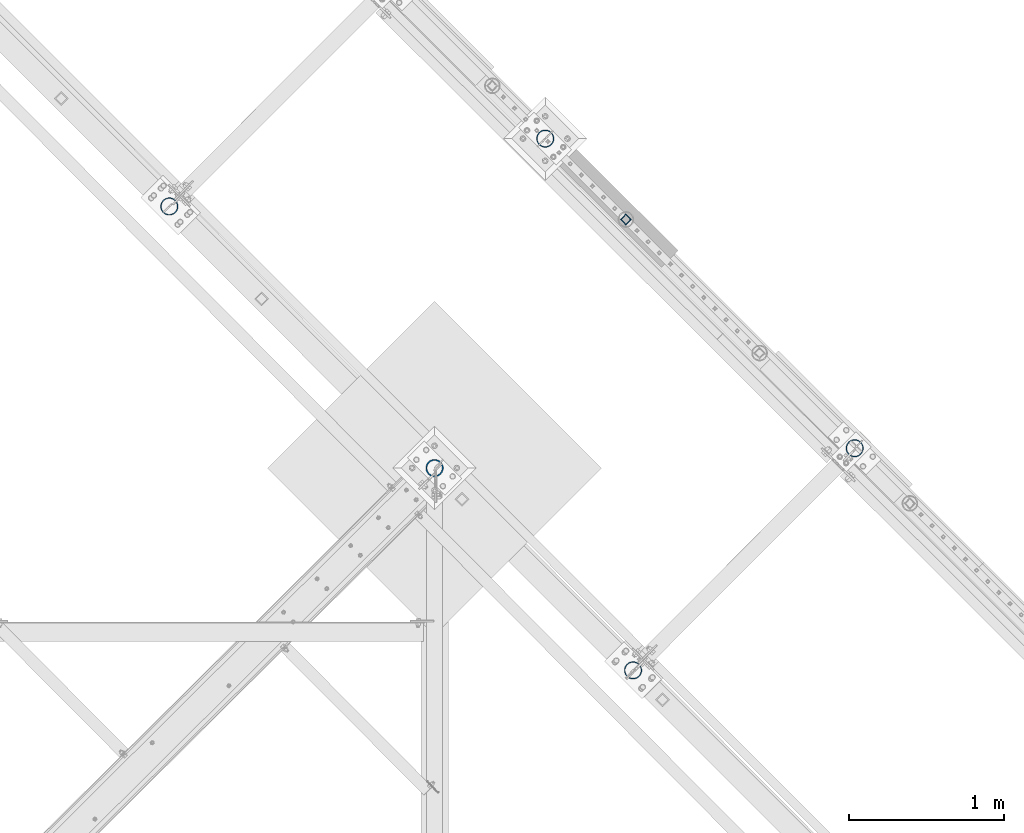
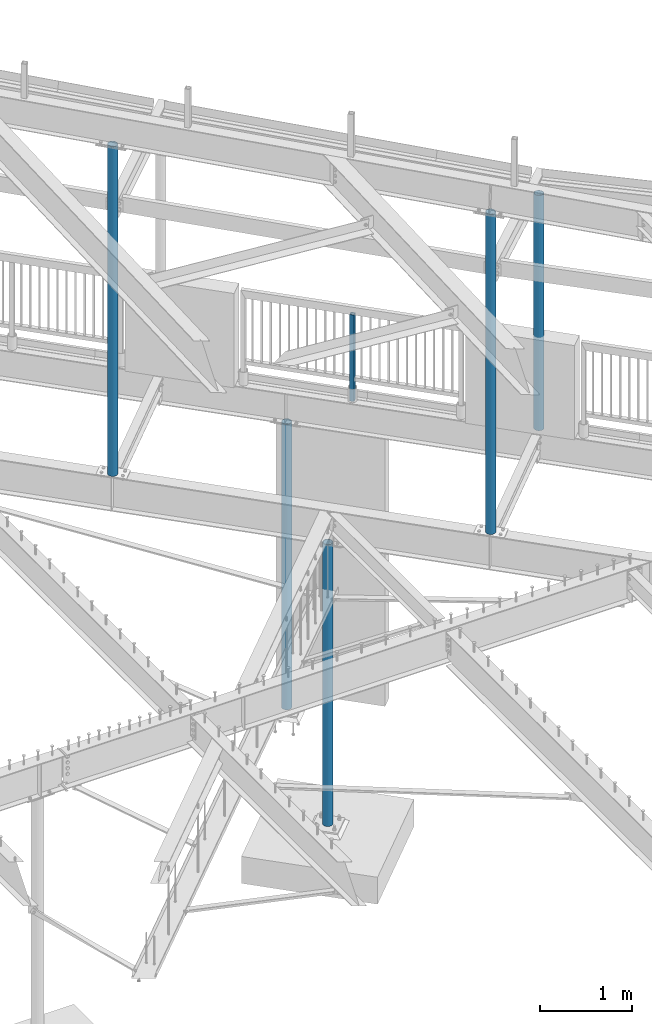
# One storey, part 138 of 975: 6 columns.
"""IFC2X3 building model written with IfcOpenShell, lengths in millimetres."""

from ifc_helpers import new_model, si_unit, frame, origin_with_axes, place, context, subcontext, project, spatial, faceted_brep, material, type_object, element, save


model = new_model("IFC2X3")

# Units and contexts
model_context = context("Model", 3, precision=1e-05, world=origin_with_axes())
body_context = subcontext(model_context, "Body", "Model", "MODEL_VIEW")
ifc_project = project(units=[si_unit("LENGTHUNIT", "METRE", prefix="MILLI"), si_unit("AREAUNIT", "SQUARE_METRE"), si_unit("VOLUMEUNIT", "CUBIC_METRE"), si_unit("MASSUNIT", "GRAM", prefix="KILO"), si_unit("TIMEUNIT", "SECOND"), si_unit("PLANEANGLEUNIT", "RADIAN"), si_unit("SOLIDANGLEUNIT", "STERADIAN"), si_unit("THERMODYNAMICTEMPERATUREUNIT", "DEGREE_CELSIUS"), si_unit("LUMINOUSINTENSITYUNIT", "LUMEN")], contexts=[model_context])

# Site, building, storey
site_placement = place(None, origin_with_axes())
site = spatial("IfcSite", under=ifc_project, at=site_placement, CompositionType="ELEMENT")
building_placement = place(site_placement, origin_with_axes())
building = spatial("IfcBuilding", under=site, at=building_placement, Name="Undefined", CompositionType="ELEMENT")
storey_placement = place(building_placement, origin_with_axes())
storey = spatial("IfcBuildingStorey", under=building, at=storey_placement, Name="Undefined", CompositionType="ELEMENT", Elevation=0.0)

# Columns
ifc_material_1 = material()
column_type_1 = type_object("IfcColumnType", Name="HSS2X2X.188_TUBES", PredefinedType="NOTDEFINED")
column_1_placement = place(storey_placement, frame((31066.8731973681, 17567.8342614889, 3937.00071954323), z_axis=(-0.707106781186601, 0.707106781186494, 2.36468622460961e-14), x_axis=(-5.04999999806568e-07, 5.04999999806568e-07, 0.999999999999745)))
element("IfcColumn", 1, at=column_1_placement, inside=storey, type_object=column_type_1, material=ifc_material_1, Name="HANDRAIL", ObjectType="HSS2X2X.188_TUBES", context=body_context, shape_type="Brep", body=[
    faceted_brep([(0.0, 20.6374999999753, -20.6375000000298), (0.0, -20.6375000000153, -20.6375000000153), (1142.9992657244, -20.6374999999534, -20.6375000019689), (1142.99926572435, 20.6374999999462, -20.6375000019689), (0.0, -20.6374999999825, 20.6375000000335), (1142.99929520217, -20.6374999999607, 20.6374999979416), (0.0, 20.6375000000116, 20.6375000000189), (1142.99929520212, 20.6374999999462, 20.6374999979416), (0.0, 25.3999999999724, -25.4000000000342), (0.0, 25.400000000016, 25.4000000000196), (1142.99929860339, 25.399999999936, 25.3999999979333), (1142.99926232306, 25.399999999936, -25.4000000019587), (0.0, -25.399999999976, 25.4000000000378), (1142.99929860346, -25.3999999999432, 25.3999999979333), (0.0, -25.400000000016, -25.4000000000196), (1142.99926232313, -25.3999999999432, -25.4000000019605)], [[[0, 1, 2, 3]], [[1, 4, 5, 2]], [[4, 6, 7, 5]], [[6, 0, 3, 7]], [[8, 9, 10, 11]], [[9, 12, 13, 10]], [[12, 14, 15, 13]], [[14, 8, 11, 15]], [[13, 15, 11, 10], [5, 7, 3, 2]], [[14, 12, 9, 8], [6, 4, 1, 0]]]),
])
ifc_material_2 = material(Name="STEEL/A53")
column_type_2 = type_object("IfcColumnType", Name="PIPE4STD", PredefinedType="NOTDEFINED")
column_2_placement = place(storey_placement, frame((31113.0694143629, 14658.8024995129, 3937.0), z_axis=(0.707106781186548, 0.707106781186548, 0.0), x_axis=(0.0, 0.0, 1.0)))
element("IfcColumn", 2, at=column_2_placement, inside=storey, type_object=column_type_2, material=ifc_material_2, Name="COLUMN", ObjectType="PIPE4STD", context=body_context, shape_type="Brep", body=[
    faceted_brep([(12.7000000000007, -51.1301999999359, 6.54836185276508e-11), (12.7000000000007, -48.6277098894352, 15.8001007258354), (4236.66741801943, -48.6277098894352, 15.8001007258354), (4236.74242044237, -51.1301999999359, 6.54836185276508e-11), (12.7000000000007, -41.3652007257788, 30.0535775067838), (4236.44958269599, -41.3652007257788, 30.0535775067838), (12.7000000000007, -30.0535775067819, 41.3652007257842), (4236.11023771126, -30.0535775067819, 41.3652007257842), (12.7000000000007, -15.8001007258317, 48.6277098894388), (4235.6826005167, -15.8001007258317, 48.6277098894388), (12.7000000000007, -6.00266503170133e-11, 51.1301999999414), (4235.20853122043, -6.00266503170133e-11, 51.1301999999414), (12.7000000000007, 15.8001007257153, 48.6277098894025), (4234.73443502822, 15.8001007257153, 48.6277098894025), (12.7000000000007, 30.0535775066819, 41.3652007257042), (4234.30671977857, 30.0535775066819, 41.3652007257042), (12.7000000000007, 41.3652007257078, 30.0535775066783), (4233.96725322019, 41.3652007257078, 30.0535775066783), (12.7000000000007, 48.6277098894061, 15.8001007257117), (4233.74926470502, 48.6277098894061, 15.8001007257117), (12.7000000000007, 51.1301999999469, -6.54836185276508e-11), (4233.67409246773, 51.1301999999469, -6.54836185276508e-11), (12.7000000000007, 48.6277098894425, -15.8001007258354), (4233.74909489068, 48.6277098894425, -15.8001007258354), (12.7000000000007, 41.3652007257861, -30.0535775067838), (4233.96693021412, 41.3652007257861, -30.0535775067838), (12.7000000000007, 30.0535775067892, -41.3652007257842), (4234.30627519885, 30.0535775067892, -41.3652007257842), (12.7000000000007, 15.800100725839, -48.6277098894388), (4234.73391239341, 15.800100725839, -48.6277098894388), (12.7000000000007, 7.09405867382884e-11, -51.1301999999414), (4235.20798168967, 7.09405867382884e-11, -51.1301999999414), (12.7000000000007, -15.8001007257044, -48.6277098893988), (4235.68207788189, -15.8001007257044, -48.6277098893988), (12.7000000000007, -30.0535775066746, -41.3652007257042), (4236.10979313153, -30.0535775066746, -41.3652007257042), (12.7000000000007, -41.3652007257006, -30.0535775066746), (4236.44925968991, -41.3652007257006, -30.0535775066746), (12.7000000000007, -48.6277098893952, -15.800100725708), (4236.66724820508, -48.6277098893952, -15.800100725708), (12.7000000000007, -57.149999999936, 7.27595761418343e-11), (12.7000000000007, -54.3528799061787, -17.6603212284354), (4236.83902219652, -54.3528799061787, -17.6603212284354), (4236.92304481644, -57.149999999936, 7.27595761418343e-11), (12.7000000000007, -46.2353212284306, -33.5919271684179), (4236.59536886361, -46.2353212284306, -33.5919271684179), (12.7000000000007, -33.5919271684143, -46.2353212284324), (4236.21593530358, -33.5919271684143, -46.2353212284324), (12.7000000000007, -17.6603212284317, -54.3528799061824), (4235.73786311694, -17.6603212284317, -54.3528799061824), (12.7000000000007, 7.45785655453801e-11, -57.149999999936), (4235.20794934025, 7.45785655453801e-11, -57.149999999936), (12.7000000000007, 17.6603212285845, -54.3528799062296), (4234.67806562609, 17.6603212285845, -54.3528799062296), (12.7000000000007, 33.5919271685379, -46.2353212285198), (4234.20008068433, 33.5919271685379, -46.2353212285198), (12.7000000000007, 46.2353212285234, -33.5919271685343), (4233.82078301138, 46.2353212285234, -33.5919271685343), (12.7000000000007, 54.3528799062333, -17.6603212285772), (4233.5773009062, 54.3528799062333, -17.6603212285772), (12.7000000000007, 57.1499999999414, -7.27595761418343e-11), (4233.49346809367, 57.1499999999414, -7.27595761418343e-11), (12.7000000000007, 54.3528799061896, 17.6603212284354), (4233.57749071359, 54.3528799061896, 17.6603212284354), (12.7000000000007, 46.2353212284361, 33.5919271684179), (4233.82114404649, 46.2353212284361, 33.5919271684179), (12.7000000000007, 33.5919271684197, 46.2353212284361), (4234.20057760653, 33.5919271684197, 46.2353212284361), (12.7000000000007, 17.6603212284426, 54.3528799061824), (4234.67864979317, 17.6603212284426, 54.3528799061824), (12.7000000000007, -6.91215973347425e-11, 57.1499999999396), (4235.20856356986, -6.91215973347425e-11, 57.1499999999396), (12.7000000000007, -17.6603212285736, 54.3528799062333), (4235.73844728401, -17.6603212285736, 54.3528799062333), (12.7000000000007, -33.5919271685307, 46.2353212285234), (4236.21643222577, -33.5919271685307, 46.2353212285234), (12.7000000000007, -46.2353212285161, 33.5919271685343), (4236.59572989872, -46.2353212285161, 33.5919271685343), (12.7000000000007, -54.3528799062224, 17.6603212285772), (4236.83921200391, -54.3528799062224, 17.6603212285772)], [[[0, 1, 2, 3]], [[1, 4, 5, 2]], [[4, 6, 7, 5]], [[6, 8, 9, 7]], [[8, 10, 11, 9]], [[10, 12, 13, 11]], [[12, 14, 15, 13]], [[14, 16, 17, 15]], [[16, 18, 19, 17]], [[18, 20, 21, 19]], [[20, 22, 23, 21]], [[22, 24, 25, 23]], [[24, 26, 27, 25]], [[26, 28, 29, 27]], [[28, 30, 31, 29]], [[30, 32, 33, 31]], [[32, 34, 35, 33]], [[34, 36, 37, 35]], [[36, 38, 39, 37]], [[38, 0, 3, 39]], [[40, 41, 42, 43]], [[41, 44, 45, 42]], [[44, 46, 47, 45]], [[46, 48, 49, 47]], [[48, 50, 51, 49]], [[50, 52, 53, 51]], [[52, 54, 55, 53]], [[54, 56, 57, 55]], [[56, 58, 59, 57]], [[58, 60, 61, 59]], [[60, 62, 63, 61]], [[62, 64, 65, 63]], [[64, 66, 67, 65]], [[66, 68, 69, 67]], [[68, 70, 71, 69]], [[70, 72, 73, 71]], [[72, 74, 75, 73]], [[74, 76, 77, 75]], [[76, 78, 79, 77]], [[78, 40, 43, 79]], [[45, 47, 49, 51, 53, 55, 57, 59, 61, 63, 65, 67, 69, 71, 73, 75, 77, 79, 43, 42], [5, 7, 9, 11, 13, 15, 17, 19, 21, 23, 25, 27, 29, 31, 33, 35, 37, 39, 3, 2]], [[78, 76, 74, 72, 70, 68, 66, 64, 62, 60, 58, 56, 54, 52, 50, 48, 46, 44, 41, 40], [38, 36, 34, 32, 30, 28, 26, 24, 22, 20, 18, 16, 14, 12, 10, 8, 6, 4, 1, 0]]]),
])
column_3_placement = place(storey_placement, frame((32542.8595833266, 16091.7904166791, 3937.0), z_axis=(0.707106781186548, 0.707106781186548, 0.0), x_axis=(0.0, 0.0, 1.0)))
element("IfcColumn", 3, at=column_3_placement, inside=storey, type_object=column_type_2, material=ifc_material_2, Name="COLUMN", ObjectType="PIPE4STD", context=body_context, shape_type="Brep", body=[
    faceted_brep([(12.7000000000007, -51.1301999999359, 6.54836185276508e-11), (12.7000000000007, -48.6277098894352, 15.8001007258354), (3112.73367698093, -48.6277098894407, 15.8001007258354), (3113.92291634242, -51.1301999999414, 6.54836185276508e-11), (12.7000000000007, -41.3652007257788, 30.0535775067838), (3111.66141610372, -41.3652007257788, 30.0535775067838), (12.7000000000007, -30.0535775067819, 41.3652007257842), (3110.81109407631, -30.0535775067819, 41.3652007257842), (12.7000000000007, -15.8001007258317, 48.6277098894388), (3110.2659463433, -15.8001007258335, 48.6277098894425), (12.7000000000007, -6.00266503170133e-11, 51.1301999999414), (3110.07933576305, -6.54836185276508e-11, 51.1301999999414), (12.7000000000007, 15.8001007257153, 48.6277098894025), (3110.26952907935, 15.8001007257099, 48.6277098893988), (12.7000000000007, 30.0535775066819, 41.3652007257042), (3110.81790884526, 30.0535775066801, 41.3652007257042), (12.7000000000007, 41.3652007257078, 30.0535775066783), (3111.67079582849, 41.3652007257078, 30.0535775066819), (12.7000000000007, 48.6277098894061, 15.8001007257117), (3112.74470350872, 48.6277098894006, 15.8001007257117), (12.7000000000007, 51.1301999999469, -6.54836185276508e-11), (3113.93451031984, 51.1301999999414, -6.54836185276508e-11), (12.7000000000007, 48.6277098894425, -15.8001007258354), (3115.12374968133, 48.6277098894407, -15.8001007258354), (12.7000000000007, 41.3652007257861, -30.0535775067838), (3116.19601055854, 41.3652007257842, -30.0535775067838), (12.7000000000007, 30.0535775067892, -41.3652007257842), (3117.04633258595, 30.0535775067874, -41.365200725777), (12.7000000000007, 15.800100725839, -48.6277098894388), (3117.59148031896, 15.8001007258335, -48.6277098894352), (12.7000000000007, 7.09405867382884e-11, -51.1301999999414), (3117.77809089921, 6.54836185276508e-11, -51.1301999999414), (12.7000000000007, -15.8001007257044, -48.6277098893988), (3117.58789758291, -15.8001007257099, -48.6277098894061), (12.7000000000007, -30.0535775066746, -41.3652007257042), (3117.039517817, -30.0535775066746, -41.3652007257042), (12.7000000000007, -41.3652007257006, -30.0535775066746), (3116.18663083377, -41.3652007257024, -30.0535775066746), (12.7000000000007, -48.6277098893952, -15.800100725708), (3115.11272315354, -48.6277098894006, -15.8001007257117), (12.7000000000007, -57.149999999936, 7.27595761418343e-11), (12.7000000000007, -54.3528799061787, -17.6603212284354), (3115.25212222354, -54.3528799061842, -17.6603212284317), (3113.92223383555, -57.149999999936, 7.27595761418343e-11), (12.7000000000007, -46.2353212284306, -33.5919271684179), (3116.45246612841, -46.2353212284306, -33.5919271684179), (12.7000000000007, -33.5919271684143, -46.2353212284324), (3117.40576752547, -33.5919271684143, -46.2353212284361), (12.7000000000007, -17.6603212284317, -54.3528799061824), (3118.01871063192, -17.6603212284372, -54.3528799061824), (12.7000000000007, 7.45785655453801e-11, -57.149999999936), (3118.23129630589, 7.45785655453801e-11, -57.149999999936), (12.7000000000007, 17.6603212285845, -54.3528799062296), (3118.02271518042, 17.6603212285809, -54.3528799062333), (12.7000000000007, 33.5919271685379, -46.2353212285198), (3117.41338462936, 33.5919271685379, -46.2353212285234), (12.7000000000007, 46.2353212285234, -33.5919271685343), (3116.4629501725, 46.2353212285198, -33.5919271685343), (12.7000000000007, 54.3528799062333, -17.6603212285772), (3115.26444695653, 54.3528799062296, -17.6603212285772), (12.7000000000007, 57.1499999999414, -7.27595761418343e-11), (3113.93519282671, 57.1499999999378, -7.27595761418343e-11), (12.7000000000007, 54.3528799061896, 17.6603212284354), (3112.60530443872, 54.3528799061842, 17.660321228439), (12.7000000000007, 46.2353212284361, 33.5919271684179), (3111.40496053385, 46.2353212284361, 33.5919271684179), (12.7000000000007, 33.5919271684197, 46.2353212284361), (3110.45165913679, 33.5919271684197, 46.2353212284361), (12.7000000000007, 17.6603212284426, 54.3528799061824), (3109.83871603034, 17.6603212284372, 54.3528799061824), (12.7000000000007, -6.91215973347425e-11, 57.1499999999396), (3109.62613035637, -7.27595761418343e-11, 57.149999999936), (12.7000000000007, -17.6603212285736, 54.3528799062333), (3109.83471148184, -17.6603212285791, 54.3528799062333), (12.7000000000007, -33.5919271685307, 46.2353212285234), (3110.4440420329, -33.5919271685361, 46.2353212285234), (12.7000000000007, -46.2353212285161, 33.5919271685343), (3111.39447648976, -46.2353212285179, 33.5919271685343), (12.7000000000007, -54.3528799062224, 17.6603212285772), (3112.59297970573, -54.3528799062278, 17.6603212285772)], [[[0, 1, 2, 3]], [[1, 4, 5, 2]], [[4, 6, 7, 5]], [[6, 8, 9, 7]], [[8, 10, 11, 9]], [[10, 12, 13, 11]], [[12, 14, 15, 13]], [[14, 16, 17, 15]], [[16, 18, 19, 17]], [[18, 20, 21, 19]], [[20, 22, 23, 21]], [[22, 24, 25, 23]], [[24, 26, 27, 25]], [[26, 28, 29, 27]], [[28, 30, 31, 29]], [[30, 32, 33, 31]], [[32, 34, 35, 33]], [[34, 36, 37, 35]], [[36, 38, 39, 37]], [[38, 0, 3, 39]], [[40, 41, 42, 43]], [[41, 44, 45, 42]], [[44, 46, 47, 45]], [[46, 48, 49, 47]], [[48, 50, 51, 49]], [[50, 52, 53, 51]], [[52, 54, 55, 53]], [[54, 56, 57, 55]], [[56, 58, 59, 57]], [[58, 60, 61, 59]], [[60, 62, 63, 61]], [[62, 64, 65, 63]], [[64, 66, 67, 65]], [[66, 68, 69, 67]], [[68, 70, 71, 69]], [[70, 72, 73, 71]], [[72, 74, 75, 73]], [[74, 76, 77, 75]], [[76, 78, 79, 77]], [[78, 40, 43, 79]], [[45, 47, 49, 51, 53, 55, 57, 59, 61, 63, 65, 67, 69, 71, 73, 75, 77, 79, 43, 42], [5, 7, 9, 11, 13, 15, 17, 19, 21, 23, 25, 27, 29, 31, 33, 35, 37, 39, 3, 2]], [[78, 76, 74, 72, 70, 68, 66, 64, 62, 60, 58, 56, 54, 52, 50, 48, 46, 44, 41, 40], [38, 36, 34, 32, 30, 28, 26, 24, 22, 20, 18, 16, 14, 12, 10, 8, 6, 4, 1, 0]]]),
])
column_4_placement = place(storey_placement, frame((28121.1711526895, 17651.7729277995, 3937.0), z_axis=(0.707106781186548, 0.707106781186548, 0.0), x_axis=(0.0, 0.0, 1.0)))
element("IfcColumn", 4, at=column_4_placement, inside=storey, type_object=column_type_2, material=ifc_material_2, Name="COLUMN", ObjectType="PIPE4STD", context=body_context, shape_type="Brep", body=[
    faceted_brep([(12.7000000000007, -51.1301999999359, 6.54836185276508e-11), (12.7000000000007, -48.6277098894352, 15.8001007258354), (4363.64701022545, -48.6277098893579, 15.8001007257517), (4363.7220126484, -51.1301999998786, -3.63797880709171e-12), (12.7000000000007, -41.3652007257788, 30.0535775067838), (4363.42917490202, -41.3652007256887, 30.0535775066928), (12.7000000000007, -30.0535775067819, 41.3652007257842), (4363.08982991728, -30.0535775066919, 41.365200725686), (12.7000000000007, -15.8001007258317, 48.6277098894388), (4362.66219272272, -15.8001007257544, 48.6277098893588), (12.7000000000007, -6.00266503170133e-11, 51.1301999999414), (4362.18812342646, -2.72848410531878e-12, 51.1301999998723), (12.7000000000007, 15.8001007257153, 48.6277098894025), (4361.71402723424, 15.8001007257508, 48.6277098893552), (12.7000000000007, 30.0535775066819, 41.3652007257042), (4361.2863119846, 30.0535775066919, 41.3652007256896), (12.7000000000007, 41.3652007257078, 30.0535775066783), (4360.94684542622, 41.3652007256906, 30.0535775066928), (12.7000000000007, 48.6277098894061, 15.8001007257117), (4360.72885691104, 48.6277098893561, 15.8001007257517), (12.7000000000007, 51.1301999999469, -6.54836185276508e-11), (4360.65368467376, 51.130199999875, -3.63797880709171e-12), (12.7000000000007, 48.6277098894425, -15.8001007258354), (4360.7286870967, 48.6277098893561, -15.8001007257517), (12.7000000000007, 41.3652007257861, -30.0535775067838), (4360.94652242014, 41.3652007256887, -30.0535775066928), (12.7000000000007, 30.0535775067892, -41.3652007257842), (4361.28586740487, 30.0535775066919, -41.3652007256896), (12.7000000000007, 15.800100725839, -48.6277098894388), (4361.71350459943, 15.8001007257526, -48.6277098893588), (12.7000000000007, 7.09405867382884e-11, -51.1301999999414), (4362.18757389569, -9.09494701772928e-13, -51.1301999998796), (12.7000000000007, -15.8001007257044, -48.6277098893988), (4362.66167008791, -15.8001007257544, -48.6277098893588), (12.7000000000007, -30.0535775066746, -41.3652007257042), (4363.08938533756, -30.0535775066919, -41.3652007256933), (12.7000000000007, -41.3652007257006, -30.0535775066746), (4363.42885189594, -41.3652007256906, -30.0535775066928), (12.7000000000007, -48.6277098893952, -15.800100725708), (4363.64684041111, -48.6277098893597, -15.8001007257553), (12.7000000000007, -57.149999999936, 7.27595761418343e-11), (12.7000000000007, -54.3528799061787, -17.6603212284354), (4363.81861440254, -54.3528799061378, -17.6603212284863), (4363.90263702246, -57.1499999998659, -3.63797880709171e-12), (12.7000000000007, -46.2353212284306, -33.5919271684179), (4363.57496106964, -46.235321228417, -33.5919271684361), (12.7000000000007, -33.5919271684143, -46.2353212284324), (4363.1955275096, -33.5919271684334, -46.2353212284179), (12.7000000000007, -17.6603212284317, -54.3528799061824), (4362.71745532296, -17.6603212284872, -54.3528799061387), (12.7000000000007, 7.45785655453801e-11, -57.149999999936), (4362.18754154627, -9.09494701772928e-13, -57.1499999998668), (12.7000000000007, 17.6603212285845, -54.3528799062296), (4361.65765783211, 17.6603212284836, -54.3528799061351), (12.7000000000007, 33.5919271685379, -46.2353212285198), (4361.17967289035, 33.5919271684334, -46.2353212284179), (12.7000000000007, 46.2353212285234, -33.5919271685343), (4360.8003752174, 46.2353212284188, -33.5919271684361), (12.7000000000007, 54.3528799062333, -17.6603212285772), (4360.55689311222, 54.3528799061323, -17.6603212284863), (12.7000000000007, 57.1499999999414, -7.27595761418343e-11), (4360.47306029969, 57.1499999998659, 0.0), (12.7000000000007, 54.3528799061896, 17.6603212284354), (4360.55708291961, 54.3528799061341, 17.6603212284826), (12.7000000000007, 46.2353212284361, 33.5919271684179), (4360.80073625251, 46.235321228417, 33.5919271684324), (12.7000000000007, 33.5919271684197, 46.2353212284361), (4361.18016981255, 33.5919271684334, 46.2353212284179), (12.7000000000007, 17.6603212284426, 54.3528799061824), (4361.65824199919, 17.6603212284836, 54.3528799061351), (12.7000000000007, -6.91215973347425e-11, 57.1499999999396), (4362.18815577589, 9.09494701772928e-13, 57.1499999998668), (12.7000000000007, -17.6603212285736, 54.3528799062333), (4362.71803949004, -17.6603212284872, 54.3528799061314), (12.7000000000007, -33.5919271685307, 46.2353212285234), (4363.1960244318, -33.5919271684334, 46.2353212284179), (12.7000000000007, -46.2353212285161, 33.5919271685343), (4363.57532210475, -46.2353212284188, 33.5919271684324), (12.7000000000007, -54.3528799062224, 17.6603212285772), (4363.81880420994, -54.352879906136, 17.6603212284826)], [[[0, 1, 2, 3]], [[1, 4, 5, 2]], [[4, 6, 7, 5]], [[6, 8, 9, 7]], [[8, 10, 11, 9]], [[10, 12, 13, 11]], [[12, 14, 15, 13]], [[14, 16, 17, 15]], [[16, 18, 19, 17]], [[18, 20, 21, 19]], [[20, 22, 23, 21]], [[22, 24, 25, 23]], [[24, 26, 27, 25]], [[26, 28, 29, 27]], [[28, 30, 31, 29]], [[30, 32, 33, 31]], [[32, 34, 35, 33]], [[34, 36, 37, 35]], [[36, 38, 39, 37]], [[38, 0, 3, 39]], [[40, 41, 42, 43]], [[41, 44, 45, 42]], [[44, 46, 47, 45]], [[46, 48, 49, 47]], [[48, 50, 51, 49]], [[50, 52, 53, 51]], [[52, 54, 55, 53]], [[54, 56, 57, 55]], [[56, 58, 59, 57]], [[58, 60, 61, 59]], [[60, 62, 63, 61]], [[62, 64, 65, 63]], [[64, 66, 67, 65]], [[66, 68, 69, 67]], [[68, 70, 71, 69]], [[70, 72, 73, 71]], [[72, 74, 75, 73]], [[74, 76, 77, 75]], [[76, 78, 79, 77]], [[78, 40, 43, 79]], [[45, 47, 49, 51, 53, 55, 57, 59, 61, 63, 65, 67, 69, 71, 73, 75, 77, 79, 43, 42], [5, 7, 9, 11, 13, 15, 17, 19, 21, 23, 25, 27, 29, 31, 33, 35, 37, 39, 3, 2]], [[78, 76, 74, 72, 70, 68, 66, 64, 62, 60, 58, 56, 54, 52, 50, 48, 46, 44, 41, 40], [38, 36, 34, 32, 30, 28, 26, 24, 22, 20, 18, 16, 14, 12, 10, 8, 6, 4, 1, 0]]]),
])
column_5_placement = place(storey_placement, frame((30546.675, 18089.5625, -266.7), z_axis=(0.707106781186548, 0.707106781186548, 0.0), x_axis=(0.0, 0.0, 1.0)))
element("IfcColumn", 5, at=column_5_placement, inside=storey, type_object=column_type_2, material=ifc_material_2, Name="COLUMN", ObjectType="PIPE4STD", context=body_context, shape_type="Brep", body=[
    faceted_brep([(19.0500000000025, -51.1301999999996, 0.0), (19.0500000000025, -48.6277098894743, 15.8001007257917), (3787.775, -48.6277098893624, 15.8001007257553), (3787.775, -51.1301999998759, 3.63797880709171e-12), (19.0500000000025, -41.3652007257897, 30.0535775067656), (3787.775, -41.3652007256969, 30.0535775066928), (19.0500000000025, -30.0535775067647, 41.3652007257915), (3787.775, -30.0535775066892, 41.3652007256933), (19.0500000000025, -15.8001007257899, 48.6277098894752), (3787.775, -15.8001007257553, 48.6277098893624), (19.0500000000025, 0.0, 51.1301999999996), (3787.775, -7.27595761418343e-12, 51.1301999998796), (19.0500000000025, 15.8001007257899, 48.6277098894752), (3787.775, 15.8001007257481, 48.6277098893606), (19.0500000000025, 30.0535775067647, 41.3652007257915), (3787.775, 30.0535775066892, 41.3652007256915), (19.0500000000025, 41.3652007257897, 30.0535775067656), (3787.775, 41.3652007256824, 30.0535775066928), (19.0500000000025, 48.6277098894743, 15.8001007257917), (3787.775, 48.6277098893552, 15.8001007257553), (19.0500000000025, 51.1301999999996, 0.0), (3787.775, 51.1301999998759, 1.81898940354586e-12), (19.0500000000025, 48.6277098894743, -15.8001007257917), (3787.775, 48.6277098893552, -15.8001007257481), (19.0500000000025, 41.3652007257897, -30.0535775067656), (3787.775, 41.3652007256896, -30.0535775066874), (19.0500000000025, 30.0535775067647, -41.3652007257915), (3787.775, 30.0535775066892, -41.3652007256878), (19.0500000000025, 15.8001007257899, -48.6277098894752), (3787.775, 15.8001007257481, -48.6277098893552), (19.0500000000025, 0.0, -51.1301999999996), (3787.775, 0.0, -51.1301999998741), (19.0500000000025, -15.8001007257899, -48.6277098894752), (3787.775, -15.8001007257553, -48.6277098893552), (19.0500000000025, -30.0535775067647, -41.3652007257915), (3787.775, -30.0535775066892, -41.365200725686), (19.0500000000025, -41.3652007257897, -30.0535775067656), (3787.775, -41.3652007256896, -30.0535775066874), (19.0500000000025, -48.6277098894743, -15.8001007257917), (3787.775, -48.6277098893624, -15.8001007257499), (19.0500000000025, -57.1499999999996, 0.0), (19.0500000000025, -54.3528799062678, -17.6603212285299), (3787.775, -54.3528799061387, -17.6603212284826), (3787.775, -57.1499999998705, 3.63797880709171e-12), (19.0500000000025, -46.2353212285279, -33.5919271685161), (3787.775, -46.2353212284215, -33.5919271684324), (19.0500000000025, -33.5919271685152, -46.235321228527), (3787.775, -33.5919271684397, -46.2353212284161), (19.0500000000025, -17.6603212285281, -54.3528799062697), (3787.775, -17.6603212284899, -54.3528799061332), (19.0500000000025, 0.0, -57.1500000000015), (3787.775, 0.0, -57.1499999998614), (19.0500000000025, 17.6603212285281, -54.3528799062697), (3787.775, 17.6603212284826, -54.3528799061314), (19.0500000000025, 33.5919271685152, -46.235321228527), (3787.775, 33.5919271684324, -46.2353212284143), (19.0500000000025, 46.2353212285279, -33.5919271685161), (3787.775, 46.2353212284143, -33.5919271684324), (19.0500000000025, 54.3528799062678, -17.6603212285299), (3787.775, 54.3528799061314, -17.6603212284826), (19.0500000000025, 57.1499999999996, 0.0), (3787.775, 57.1499999998632, 1.81898940354586e-12), (19.0500000000025, 54.3528799062678, 17.6603212285299), (3787.775, 54.3528799061314, 17.6603212284881), (19.0500000000025, 46.2353212285279, 33.5919271685161), (3787.775, 46.2353212284143, 33.5919271684379), (19.0500000000025, 33.5919271685152, 46.235321228527), (3787.775, 33.5919271684324, 46.2353212284215), (19.0500000000025, 17.6603212285281, 54.3528799062697), (3787.775, 17.6603212284826, 54.3528799061387), (19.0500000000025, 0.0, 57.1500000000015), (3787.775, -7.27595761418343e-12, 57.1499999998668), (19.0500000000025, -17.6603212285281, 54.3528799062697), (3787.775, -17.6603212284899, 54.3528799061369), (19.0500000000025, -33.5919271685152, 46.235321228527), (3787.775, -33.5919271684397, 46.2353212284197), (19.0500000000025, -46.2353212285279, 33.5919271685161), (3787.775, -46.2353212284215, 33.5919271684379), (19.0500000000025, -54.3528799062678, 17.6603212285299), (3787.775, -54.3528799061387, 17.6603212284881)], [[[0, 1, 2, 3]], [[1, 4, 5, 2]], [[4, 6, 7, 5]], [[6, 8, 9, 7]], [[8, 10, 11, 9]], [[10, 12, 13, 11]], [[12, 14, 15, 13]], [[14, 16, 17, 15]], [[16, 18, 19, 17]], [[18, 20, 21, 19]], [[20, 22, 23, 21]], [[22, 24, 25, 23]], [[24, 26, 27, 25]], [[26, 28, 29, 27]], [[28, 30, 31, 29]], [[30, 32, 33, 31]], [[32, 34, 35, 33]], [[34, 36, 37, 35]], [[36, 38, 39, 37]], [[38, 0, 3, 39]], [[40, 41, 42, 43]], [[41, 44, 45, 42]], [[44, 46, 47, 45]], [[46, 48, 49, 47]], [[48, 50, 51, 49]], [[50, 52, 53, 51]], [[52, 54, 55, 53]], [[54, 56, 57, 55]], [[56, 58, 59, 57]], [[58, 60, 61, 59]], [[60, 62, 63, 61]], [[62, 64, 65, 63]], [[64, 66, 67, 65]], [[66, 68, 69, 67]], [[68, 70, 71, 69]], [[70, 72, 73, 71]], [[72, 74, 75, 73]], [[74, 76, 77, 75]], [[76, 78, 79, 77]], [[78, 40, 43, 79]], [[45, 47, 49, 51, 53, 55, 57, 59, 61, 63, 65, 67, 69, 71, 73, 75, 77, 79, 43, 42], [5, 7, 9, 11, 13, 15, 17, 19, 21, 23, 25, 27, 29, 31, 33, 35, 37, 39, 3, 2]], [[78, 76, 74, 72, 70, 68, 66, 64, 62, 60, 58, 56, 54, 52, 50, 48, 46, 44, 41, 40], [38, 36, 34, 32, 30, 28, 26, 24, 22, 20, 18, 16, 14, 12, 10, 8, 6, 4, 1, 0]]]),
])
column_type_3 = type_object("IfcColumnType", Name="PIPE4XS", PredefinedType="NOTDEFINED")
column_6_placement = place(storey_placement, frame((29832.3, 15963.9, -266.7), z_axis=(-0.707106781186601, 0.707106781186494, 2.36468622460961e-14), x_axis=(0.0, 0.0, 1.0)))
element("IfcColumn", 6, at=column_6_placement, inside=storey, type_object=column_type_3, material=ifc_material_2, Name="COLUMN", ObjectType="PIPE4XS", context=body_context, shape_type="Brep", body=[
    faceted_brep([(19.050000000004, -48.5902000000006, 0.0), (19.050000000004, -46.2120263380839, 15.0151975600784), (3736.975, -46.2120263380129, 15.015197560002), (3736.975, -48.5901999999405, -6.54836185276508e-11), (19.050000000004, -39.3102975600777, 28.560602965943), (3736.975, -39.3102975599941, 28.5606029658575), (19.050000000004, -28.560602965943, 39.3102975600777), (3736.975, -28.5606029658557, 39.3102975599941), (19.050000000004, -15.0151975600784, 46.2120263380857), (3736.975, -15.0151975599983, 46.2120263380148), (19.050000000004, 0.0, 48.5901999999987), (3736.975, 6.54836185276508e-11, 48.5901999999423), (19.050000000004, 15.0151975600784, 46.2120263380857), (3736.975, 15.0151975601257, 46.212026338053), (19.050000000004, 28.560602965943, 39.3102975600777), (3736.975, 28.5606029659648, 39.3102975600723), (19.050000000004, 39.3102975600777, 28.560602965943), (3736.975, 39.3102975600741, 28.5606029659593), (19.050000000004, 46.2120263380857, 15.0151975600784), (3736.975, 46.2120263380566, 15.0151975601184), (19.050000000004, 48.5901999999987, 0.0), (3736.975, 48.5901999999478, 6.3664629124105e-11), (19.050000000004, 46.2120263380857, -15.0151975600784), (3736.975, 46.2120263380166, -15.0151975600038), (19.050000000004, 39.3102975600777, -28.560602965943), (3736.975, 39.3102975600013, -28.5606029658593), (19.050000000004, 28.560602965943, -39.3102975600777), (3736.975, 28.5606029658629, -39.3102975599959), (19.050000000004, 15.0151975600784, -46.2120263380857), (3736.975, 15.015197560002, -46.2120263380166), (19.050000000004, 0.0, -48.5901999999987), (3736.975, -5.82076609134674e-11, -48.5901999999442), (19.050000000004, -15.0151975600784, -46.2120263380857), (3736.975, -15.0151975601184, -46.2120263380548), (19.050000000004, -28.560602965943, -39.3102975600777), (3736.975, -28.5606029659575, -39.3102975600741), (19.050000000004, -39.3102975600777, -28.560602965943), (3736.975, -39.3102975600668, -28.5606029659612), (19.050000000004, -46.2120263380839, -15.0151975600784), (3736.975, -46.2120263380493, -15.0151975601202), (19.0500000000025, -57.1499999999996, 0.0), (19.0500000000025, -54.3528799062678, -17.6603212285299), (3736.975, -54.352879906226, -17.6603212285791), (3736.975, -57.149999999936, -7.27595761418343e-11), (19.0500000000025, -46.2353212285279, -33.5919271685161), (3736.975, -46.2353212285161, -33.5919271685361), (19.0500000000025, -33.5919271685152, -46.235321228527), (3736.975, -33.5919271685343, -46.2353212285216), (19.0500000000025, -17.6603212285281, -54.3528799062697), (3736.975, -17.6603212285772, -54.3528799062315), (19.0500000000025, 0.0, -57.1500000000015), (3736.975, -7.27595761418343e-11, -57.1499999999396), (19.0500000000025, 17.6603212285281, -54.3528799062697), (3736.975, 17.660321228439, -54.3528799061842), (19.0500000000025, 33.5919271685152, -46.235321228527), (3736.975, 33.5919271684215, -46.2353212284343), (19.0500000000025, 46.2353212285279, -33.5919271685161), (3736.975, 46.2353212284361, -33.5919271684179), (19.0500000000025, 54.3528799062678, -17.6603212285299), (3736.975, 54.3528799061896, -17.6603212284354), (19.0500000000025, 57.1499999999996, 0.0), (3736.975, 57.1499999999432, 7.09405867382884e-11), (19.0500000000025, 54.3528799062678, 17.6603212285299), (3736.975, 54.3528799062333, 17.6603212285772), (19.0500000000025, 46.2353212285279, 33.5919271685161), (3736.975, 46.2353212285234, 33.5919271685343), (19.0500000000025, 33.5919271685152, 46.235321228527), (3736.975, 33.5919271685416, 46.2353212285198), (19.0500000000025, 17.6603212285281, 54.3528799062697), (3736.975, 17.6603212285845, 54.3528799062296), (19.0500000000025, 0.0, 57.1500000000015), (3736.975, 8.00355337560177e-11, 57.1499999999378), (19.0500000000025, -17.6603212285281, 54.3528799062697), (3736.975, -17.6603212284317, 54.3528799061824), (19.0500000000025, -33.5919271685152, 46.235321228527), (3736.975, -33.5919271684179, 46.2353212284324), (19.0500000000025, -46.2353212285279, 33.5919271685161), (3736.975, -46.2353212284324, 33.5919271684161), (19.0500000000025, -54.3528799062678, 17.6603212285299), (3736.975, -54.3528799061824, 17.6603212284335)], [[[0, 1, 2, 3]], [[1, 4, 5, 2]], [[4, 6, 7, 5]], [[6, 8, 9, 7]], [[8, 10, 11, 9]], [[10, 12, 13, 11]], [[12, 14, 15, 13]], [[14, 16, 17, 15]], [[16, 18, 19, 17]], [[18, 20, 21, 19]], [[20, 22, 23, 21]], [[22, 24, 25, 23]], [[24, 26, 27, 25]], [[26, 28, 29, 27]], [[28, 30, 31, 29]], [[30, 32, 33, 31]], [[32, 34, 35, 33]], [[34, 36, 37, 35]], [[36, 38, 39, 37]], [[38, 0, 3, 39]], [[40, 41, 42, 43]], [[41, 44, 45, 42]], [[44, 46, 47, 45]], [[46, 48, 49, 47]], [[48, 50, 51, 49]], [[50, 52, 53, 51]], [[52, 54, 55, 53]], [[54, 56, 57, 55]], [[56, 58, 59, 57]], [[58, 60, 61, 59]], [[60, 62, 63, 61]], [[62, 64, 65, 63]], [[64, 66, 67, 65]], [[66, 68, 69, 67]], [[68, 70, 71, 69]], [[70, 72, 73, 71]], [[72, 74, 75, 73]], [[74, 76, 77, 75]], [[76, 78, 79, 77]], [[78, 40, 43, 79]], [[45, 47, 49, 51, 53, 55, 57, 59, 61, 63, 65, 67, 69, 71, 73, 75, 77, 79, 43, 42], [5, 7, 9, 11, 13, 15, 17, 19, 21, 23, 25, 27, 29, 31, 33, 35, 37, 39, 3, 2]], [[78, 76, 74, 72, 70, 68, 66, 64, 62, 60, 58, 56, 54, 52, 50, 48, 46, 44, 41, 40], [38, 36, 34, 32, 30, 28, 26, 24, 22, 20, 18, 16, 14, 12, 10, 8, 6, 4, 1, 0]]]),
])

save(model, "model.ifc")
